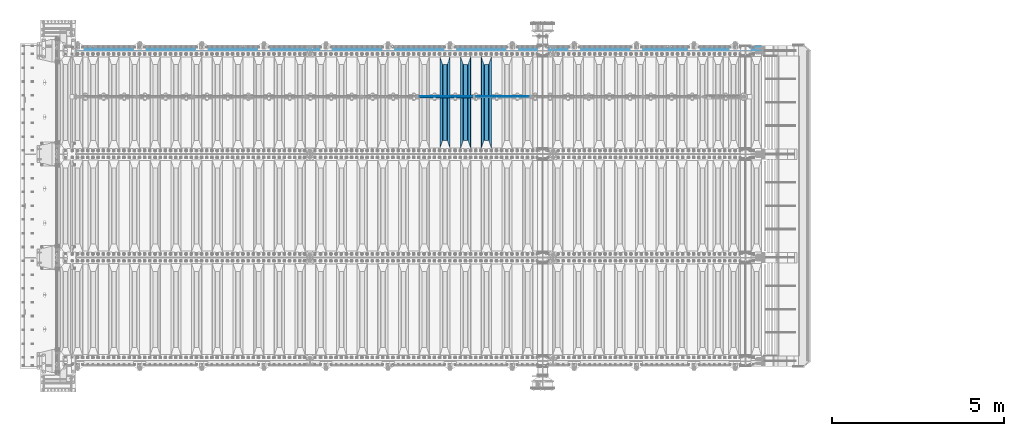
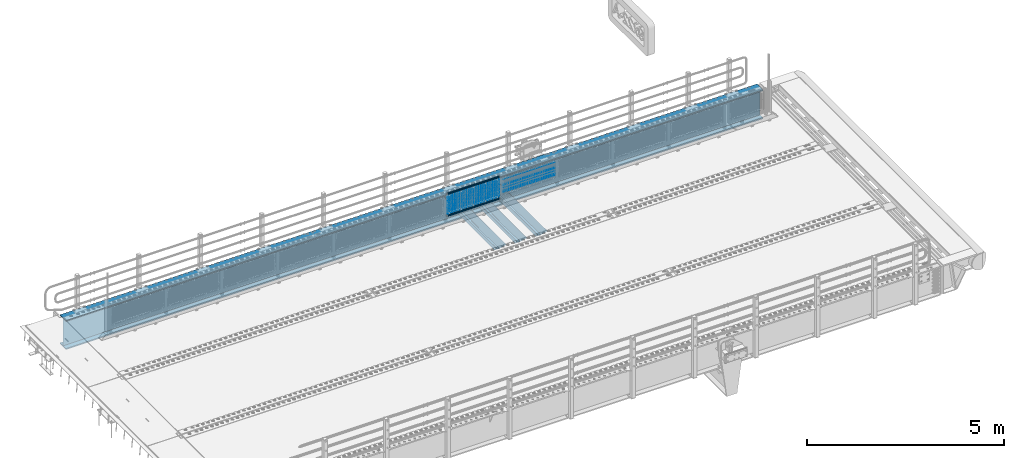
# One storey, part 135 of 270: 30 beams.
"""IFC2X3 building model written with IfcOpenShell, lengths in millimetres."""

import ifcopenshell
import ifcopenshell.guid

model = None  # the IFC model being written
_history = None  # IfcOwnerHistory: only IFC2X3 demands one
_inside = {}  # id of a spatial element -> (the spatial element, [elements in it])
_under = {}  # id of a project, library or spatial element -> (it, [spatial elements below it])
_declared = {}  # id of a project -> (the project, [libraries it declares])
_typed = {}  # id of a type object -> (the type object, [elements of that type])
_made_of = {}  # id of a material, layer set ... -> (it, [elements and type objects made of it])


def new_model(schema):
    """Start an empty IFC model of exactly this schema.

    Asked for "IFC4X3", IfcOpenShell would pick the latest addendum, in which some entities
    have other attributes; the version numbers below select the first issue.
    IFC2X3 requires an IfcOwnerHistory on every rooted entity: one is made here for all.
    """
    global model, _history
    if schema == "IFC4X3":
        model = ifcopenshell.file(schema_version=(4, 3, 0, 0))
    else:
        model = ifcopenshell.file(schema=schema)
    _inside.clear()
    _under.clear()
    _declared.clear()
    _typed.clear()
    _made_of.clear()
    _history = None
    if model.schema == "IFC2X3":
        org = make("IfcOrganization", Name="unknown")
        user = make(
            "IfcPersonAndOrganization",
            ThePerson=make("IfcPerson", FamilyName="unknown"),
            TheOrganization=org,
        )
        app = make(
            "IfcApplication",
            ApplicationDeveloper=org,
            Version="unknown",
            ApplicationFullName="unknown",
            ApplicationIdentifier="unknown",
        )
        _history = make(
            "IfcOwnerHistory",
            OwningUser=user,
            OwningApplication=app,
            ChangeAction="ADDED",
            CreationDate=0,
        )
    return model


def make(cls, **values):
    """One entity of the class cls with the attributes given. An attribute that is None is left unset."""
    return model.create_entity(
        cls, **{name: value for name, value in values.items() if value is not None}
    )


def rooted(cls, **values):
    """An entity with a GlobalId (a new one), such as an element, a storey or a relation."""
    return make(cls, GlobalId=ifcopenshell.guid.new(), OwnerHistory=_history, **values)


def si_unit(unit_type, name, prefix=None):
    """IfcSIUnit, for example si_unit("LENGTHUNIT", "METRE", prefix="MILLI")."""
    return make("IfcSIUnit", UnitType=unit_type, Prefix=prefix, Name=name)


def assignment(units):
    """IfcUnitAssignment: the units of a project."""
    return None if units is None else make("IfcUnitAssignment", Units=units)


def point(xyz):
    """IfcCartesianPoint."""
    return None if xyz is None else make("IfcCartesianPoint", Coordinates=xyz)


def direction(xyz):
    """IfcDirection."""
    return None if xyz is None else make("IfcDirection", DirectionRatios=xyz)


def frame(location, z_axis=None, x_axis=None):
    """IfcAxis2Placement3D, a coordinate frame: its origin and axes. An axis left out is left unset."""
    return make(
        "IfcAxis2Placement3D",
        Location=point(location),
        Axis=direction(z_axis),
        RefDirection=direction(x_axis),
    )


def origin_with_axes():
    """The frame at (0, 0, 0) with the z axis (0, 0, 1) and the x axis (1, 0, 0) written out."""
    return frame((0.0, 0.0, 0.0), z_axis=(0.0, 0.0, 1.0), x_axis=(1.0, 0.0, 0.0))


def place(relative_to, where):
    """IfcLocalPlacement: puts the frame where relative to a parent placement (None: the world)."""
    return make(
        "IfcLocalPlacement", PlacementRelTo=relative_to, RelativePlacement=where
    )


def context(
    kind, dimensions, precision=None, world=None, true_north=None, identifier=None
):
    """IfcGeometricRepresentationContext, for example the 3D "Model" context."""
    return make(
        "IfcGeometricRepresentationContext",
        ContextIdentifier=identifier,
        ContextType=kind,
        CoordinateSpaceDimension=dimensions,
        Precision=precision,
        WorldCoordinateSystem=world,
        TrueNorth=true_north,
    )


def subcontext(parent, identifier, kind, view, scale=None):
    """IfcGeometricRepresentationSubContext, for example "Body" below "Model"."""
    return make(
        "IfcGeometricRepresentationSubContext",
        ContextIdentifier=identifier,
        ContextType=kind,
        ParentContext=parent,
        TargetScale=scale,
        TargetView=view,
    )


def project(units=None, contexts=None):
    """IfcProject with its units and contexts."""
    return rooted(
        "IfcProject",
        Name="project",
        RepresentationContexts=contexts,
        UnitsInContext=assignment(units),
    )


def spatial(cls, under=None, at=None, **own):
    """A site, building, storey or space (cls), placed at a placement, below another one or the project."""
    s = rooted(cls, ObjectPlacement=at, **own)
    if under is not None:
        _under.setdefault(under.id(), (under, []))[1].append(s)
    return s


def faces_of(points, faces, orient=None, outer=None):
    """IfcFace entities. A face is a list of loops; a loop is a list of indices into points, from 0.

    orient and outer hold one flag for each loop. By default every Orientation is true, the
    first loop of a face is its IfcFaceOuterBound and the others are IfcFaceBound.
    """
    made = []
    for i, loops in enumerate(faces):
        bounds = []
        for j, loop in enumerate(loops):
            is_outer = j == 0 if outer is None else outer[i][j]
            bounds.append(
                make(
                    "IfcFaceOuterBound" if is_outer else "IfcFaceBound",
                    Bound=make("IfcPolyLoop", Polygon=[points[k] for k in loop]),
                    Orientation=True if orient is None else orient[i][j],
                )
            )
        made.append(make("IfcFace", Bounds=bounds))
    return made


def faceted_brep(points, faces, orient=None, outer=None, voids=None):
    """IfcFacetedBrep: a solid bounded by flat faces; with voids (closed shells), ...WithVoids."""
    shared = [point(p) for p in points]
    hull = make("IfcClosedShell", CfsFaces=faces_of(shared, faces, orient, outer))
    if voids is None:
        return make("IfcFacetedBrep", Outer=hull)
    return make(
        "IfcFacetedBrepWithVoids",
        Outer=hull,
        Voids=[
            make(cls, CfsFaces=faces_of(shared, fs, o, b)) for cls, fs, o, b in voids
        ],
    )


def shape(context_of_items, identifier, shape_type, items):
    """IfcShapeRepresentation: the items that make up one representation, for example the "Body"."""
    return make(
        "IfcShapeRepresentation",
        ContextOfItems=context_of_items,
        RepresentationIdentifier=identifier,
        RepresentationType=shape_type,
        Items=items,
    )


def material(Name=None, Category=None):
    """IfcMaterial."""
    return make("IfcMaterial", Name=Name, Category=Category)


def made_of(thing, what):
    """Note that an element or type object is made of a material, layer set ...; save() writes the relation."""
    if what is not None:
        _made_of.setdefault(what.id(), (what, []))[1].append(thing)
    return thing


def type_object(cls, material=None, **own):
    """A type object (cls), such as IfcWallType, which elements share."""
    return made_of(rooted(cls, **own), material)


def element(
    cls,
    number,
    at=None,
    inside=None,
    cuts=None,
    type_object=None,
    material=None,
    context=None,
    identifier="Body",
    shape_type=None,
    held_by="IfcProductDefinitionShape",
    body=None,
    shapes=None,
    **own,
):
    """One element of the class cls, such as IfcWall. Its Tag is "e" and its number.

    at: its placement. inside: the storey or other place that contains it. cuts: it is an
    opening in that element (IfcRelVoidsElement). A single representation is given by context,
    identifier, shape_type and body (its items); several are given by shapes. held_by: the class
    of the entity that holds the representations. save() writes the other relations.
    """
    e = rooted(cls, Tag="e%d" % number, ObjectPlacement=at, **own)
    if body is not None:
        shapes = [shape(context, identifier, shape_type, body)]
    if shapes is not None:
        e.Representation = make(held_by, Representations=shapes)
    if inside is not None:
        _inside.setdefault(inside.id(), (inside, []))[1].append(e)
    if cuts is not None:
        rooted(
            "IfcRelVoidsElement", RelatingBuildingElement=cuts, RelatedOpeningElement=e
        )
    if type_object is not None:
        _typed.setdefault(type_object.id(), (type_object, []))[1].append(e)
    return made_of(e, material)


def aggregate(whole, parts):
    """IfcRelAggregates: a whole, such as a stair, and the parts it consists of."""
    return rooted("IfcRelAggregates", RelatingObject=whole, RelatedObjects=parts)


def save(model, path):
    """Write the relations noted so far, then the file.

    IfcRelAggregates (storeys below a building ...), IfcRelContainedInSpatialStructure (elements
    in a storey), IfcRelDefinesByType, IfcRelAssociatesMaterial and IfcRelDeclares: one each for
    every whole, place, type object, material and project.
    """
    for whole, parts in _under.values():
        aggregate(whole, parts)
    for where, things in _inside.values():
        rooted(
            "IfcRelContainedInSpatialStructure",
            RelatedElements=things,
            RelatingStructure=where,
        )
    for kind, things in _typed.values():
        rooted("IfcRelDefinesByType", RelatedObjects=things, RelatingType=kind)
    for what, things in _made_of.values():
        rooted("IfcRelAssociatesMaterial", RelatedObjects=things, RelatingMaterial=what)
    for by, libraries in _declared.values():
        rooted("IfcRelDeclares", RelatingContext=by, RelatedDefinitions=libraries)
    model.write(path)


model = new_model("IFC2X3")

# Units and contexts
model_context = context("Model", 3, precision=1e-05, world=origin_with_axes())
body_context = subcontext(model_context, "Body", "Model", "MODEL_VIEW")
ifc_project = project(units=[si_unit("LENGTHUNIT", "METRE", prefix="MILLI"), si_unit("AREAUNIT", "SQUARE_METRE"), si_unit("VOLUMEUNIT", "CUBIC_METRE"), si_unit("MASSUNIT", "GRAM", prefix="KILO"), si_unit("TIMEUNIT", "SECOND"), si_unit("PLANEANGLEUNIT", "RADIAN"), si_unit("SOLIDANGLEUNIT", "STERADIAN"), si_unit("THERMODYNAMICTEMPERATUREUNIT", "DEGREE_CELSIUS"), si_unit("LUMINOUSINTENSITYUNIT", "LUMEN")], contexts=[model_context])

# Site, building, storey
site_placement = place(None, origin_with_axes())
site = spatial("IfcSite", under=ifc_project, at=site_placement, CompositionType="ELEMENT")
building_placement = place(site_placement, origin_with_axes())
building = spatial("IfcBuilding", under=site, at=building_placement, Name="Standard", CompositionType="ELEMENT")
storey_placement = place(building_placement, origin_with_axes())
storey = spatial("IfcBuildingStorey", under=building, at=storey_placement, Name="Undefined", CompositionType="ELEMENT", Elevation=0.0)

# Beams
ifc_material_1 = material(Name="STEEL/S355N")
beam_type_1 = type_object("IfcBeamType", PredefinedType="NOTDEFINED")
beam_1_placement = place(storey_placement, frame((12400.0, -17825.0, -115.0), z_axis=(0.0, 0.0, 1.0), x_axis=(0.0, 1.0, 0.0)))
element("IfcBeam", 1, at=beam_1_placement, inside=storey, type_object=beam_type_1, material=ifc_material_1, context=body_context, shape_type="Brep", body=[
    faceted_brep([(0.0, 150.0, 115.0), (0.0, 143.689999999999, 115.0), (2650.00000000297, 143.689999999999, 115.0), (2650.00000000297, 150.0, 115.0), (2650.00000000297, 142.059565218398, 110.000000003096), (2650.00000000297, 148.3695652184, 110.000000003096), (2441.90079219209, -80.1103600731112, -98.0992078077845), (2437.7588105432, -77.5672621345584, -102.241189456673), (2434.06523489747, -74.4080125315522, -105.934765102404), (2430.9108609509, -70.710272125576, -109.089139048974), (2428.37322971128, -66.5649389910068, -111.626770288588), (2426.51472138055, -62.0739139532889, -113.485278619323), (2425.38102192092, -57.3475956567672, -114.618978078955), (2424.99999999987, -52.5021667386536, -115.0), (2424.99999999987, 52.5021667386536, -115.0), (2425.38102192092, 57.3475956567672, -114.618978078955), (2426.51472138055, 62.0739139532889, -113.485278619323), (2428.37322971128, 66.5649389910068, -111.626770288588), (2430.9108609509, 70.710272125576, -109.089139048974), (2434.06523489747, 74.4080125315522, -105.934765102404), (2437.7588105432, 77.5672621345584, -102.241189456673), (2441.90079219209, 80.1103600731112, -98.0992078077846), (2446.38936140511, 81.9747917625791, -93.6106385947584), (2448.2494850041, 76.2713538057251, -91.7505149957729), (2444.62967112263, 74.76777986261, -95.3703288772456), (2441.28936334126, 72.7168944282894, -98.710636658607), (2438.31067330439, 70.1691124903846, -101.689326695487), (2435.76682334747, 67.1870637758839, -104.233176652398), (2433.72034654133, 63.8440531834895, -106.279653458539), (2432.22154950042, 60.222258798236, -107.778450499454), (2431.30727574265, 56.4107117849089, -108.692724257221), (2430.99999999987, 52.5031078186876, -109.0), (2430.99999999987, -52.5031078186876, -109.0), (2431.30727574265, -56.4107117849089, -108.692724257221), (2432.22154950042, -60.222258798236, -107.778450499454), (2433.72034654133, -63.8440531834895, -106.279653458539), (2435.76682334747, -67.1870637758839, -104.233176652398), (2438.31067330438, -70.1691124903846, -101.689326695487), (2441.28936334126, -72.7168944282894, -98.7106366586071), (2444.62967112263, -74.76777986261, -95.3703288772457), (2448.2494850041, -76.2713538057251, -91.7505149957729), (2650.00000000297, -142.059565218398, 110.000000003096), (2650.00000000297, -148.3695652184, 110.000000003096), (2446.38936140511, -81.9747917625791, -93.6106385947584), (2650.00000000297, -143.689999999999, 115.0), (2650.00000000297, -150.0, 115.0), (0.0, -143.689999999999, 115.0), (0.0, -150.0, 115.0), (0.0, -148.369565218261, 110.000000002672), (203.610638597431, -81.9747917625791, -93.6106385947584), (208.099207810457, -80.1103600731112, -98.0992078077845), (212.241189459342, -77.5672621345584, -102.241189456673), (215.934765105078, -74.4080125315522, -105.934765102404), (219.089139051644, -70.710272125576, -109.089139048974), (221.626770291259, -66.5649389910068, -111.626770288588), (223.485278621993, -62.0739139532889, -113.485278619323), (224.618978081628, -57.3475956567672, -114.618978078955), (225.00000000267, -52.5021667386536, -115.0), (225.00000000267, 52.5021667386536, -115.0), (224.618978081628, 57.3475956567672, -114.618978078955), (223.485278621993, 62.0739139532889, -113.485278619323), (221.626770291259, 66.5649389910068, -111.626770288588), (219.089139051644, 70.710272125576, -109.089139048974), (215.934765105078, 74.4080125315522, -105.934765102404), (212.241189459342, 77.5672621345584, -102.241189456673), (208.099207810457, 80.1103600731112, -98.0992078077846), (203.610638597431, 81.9747917625791, -93.6106385947584), (0.0, 148.369565218261, 110.000000002672), (0.0, 142.05956521826, 110.000000002672), (201.750514998446, 76.2713538057251, -91.7505149957729), (205.370328879915, 74.76777986261, -95.3703288772456), (208.710636661279, 72.7168944282894, -98.710636658607), (211.689326698157, 70.1691124903846, -101.689326695487), (214.233176655071, 67.1870637758839, -104.233176652398), (216.27965346121, 63.8440531834895, -106.279653458539), (217.778450502126, 60.222258798236, -107.778450499454), (218.692724259894, 56.4107117849089, -108.692724257221), (219.00000000267, 52.5031078186876, -109.0), (219.00000000267, -52.5031078186876, -109.0), (218.692724259894, -56.4107117849089, -108.692724257221), (217.778450502123, -60.222258798236, -107.778450499454), (216.27965346121, -63.8440531834895, -106.279653458539), (214.233176655071, -67.1870637758839, -104.233176652398), (211.689326698157, -70.1691124903846, -101.689326695487), (208.710636661279, -72.7168944282894, -98.7106366586071), (205.370328879915, -74.76777986261, -95.3703288772457), (201.750514998446, -76.2713538057251, -91.7505149957729), (0.0, -142.05956521826, 110.000000002672)], [[[0, 1, 2, 3]], [[3, 2, 4, 5]], [[6, 7, 8, 9, 10, 11, 12, 13, 14, 15, 16, 17, 18, 19, 20, 21, 22, 5, 4, 23, 24, 25, 26, 27, 28, 29, 30, 31, 32, 33, 34, 35, 36, 37, 38, 39, 40, 41, 42, 43]], [[44, 45, 42, 41]], [[46, 47, 45, 44]], [[43, 42, 45, 47, 48, 49]], [[6, 43, 49, 50]], [[7, 6, 50, 51]], [[8, 7, 51, 52]], [[9, 8, 52, 53]], [[10, 9, 53, 54]], [[11, 10, 54, 55]], [[12, 11, 55, 56]], [[13, 12, 56, 57]], [[14, 13, 57, 58]], [[15, 14, 58, 59]], [[16, 15, 59, 60]], [[17, 16, 60, 61]], [[18, 17, 61, 62]], [[19, 18, 62, 63]], [[20, 19, 63, 64]], [[21, 20, 64, 65]], [[22, 21, 65, 66]], [[0, 3, 5, 22, 66, 67]], [[1, 0, 67, 68]], [[23, 4, 2, 1, 68, 69]], [[24, 23, 69, 70]], [[25, 24, 70, 71]], [[26, 25, 71, 72]], [[27, 26, 72, 73]], [[28, 27, 73, 74]], [[29, 28, 74, 75]], [[30, 29, 75, 76]], [[31, 30, 76, 77]], [[32, 31, 77, 78]], [[33, 32, 78, 79]], [[34, 33, 79, 80]], [[35, 34, 80, 81]], [[36, 35, 81, 82]], [[37, 36, 82, 83]], [[38, 37, 83, 84]], [[39, 38, 84, 85]], [[40, 39, 85, 86]], [[46, 44, 41, 40, 86, 87]], [[47, 46, 87, 48]], [[86, 85, 84, 83, 82, 81, 80, 79, 78, 77, 76, 75, 74, 73, 72, 71, 70, 69, 68, 67, 66, 65, 64, 63, 62, 61, 60, 59, 58, 57, 56, 55, 54, 53, 52, 51, 50, 49, 48, 87]]]),
])
beam_2_placement = place(storey_placement, frame((11800.0, -17825.0, -115.0), z_axis=(0.0, 0.0, 1.0), x_axis=(0.0, 1.0, 0.0)))
element("IfcBeam", 2, at=beam_2_placement, inside=storey, type_object=beam_type_1, material=ifc_material_1, context=body_context, shape_type="Brep", body=[
    faceted_brep([(0.0, 150.0, 115.0), (0.0, 143.689999999999, 115.0), (2650.00000000297, 143.689999999999, 115.0), (2650.00000000297, 150.0, 115.0), (2650.00000000297, 142.059565218398, 110.000000003096), (2650.00000000297, 148.3695652184, 110.000000003096), (2441.90079219209, -80.1103600731112, -98.0992078077845), (2437.7588105432, -77.5672621345584, -102.241189456673), (2434.06523489747, -74.4080125315522, -105.934765102404), (2430.9108609509, -70.710272125576, -109.089139048974), (2428.37322971128, -66.5649389910068, -111.626770288588), (2426.51472138055, -62.0739139532889, -113.485278619323), (2425.38102192092, -57.3475956567672, -114.618978078955), (2424.99999999987, -52.5021667386536, -115.0), (2424.99999999987, 52.5021667386536, -115.0), (2425.38102192092, 57.3475956567672, -114.618978078955), (2426.51472138055, 62.0739139532889, -113.485278619323), (2428.37322971128, 66.5649389910068, -111.626770288588), (2430.9108609509, 70.710272125576, -109.089139048974), (2434.06523489747, 74.4080125315522, -105.934765102404), (2437.7588105432, 77.5672621345584, -102.241189456673), (2441.90079219209, 80.1103600731112, -98.0992078077846), (2446.38936140511, 81.9747917625791, -93.6106385947584), (2448.2494850041, 76.2713538057251, -91.7505149957729), (2444.62967112263, 74.76777986261, -95.3703288772456), (2441.28936334126, 72.7168944282894, -98.710636658607), (2438.31067330439, 70.1691124903846, -101.689326695487), (2435.76682334747, 67.1870637758839, -104.233176652398), (2433.72034654133, 63.8440531834895, -106.279653458539), (2432.22154950042, 60.222258798236, -107.778450499454), (2431.30727574265, 56.4107117849089, -108.692724257221), (2430.99999999987, 52.5031078186876, -109.0), (2430.99999999987, -52.5031078186876, -109.0), (2431.30727574265, -56.4107117849089, -108.692724257221), (2432.22154950042, -60.222258798236, -107.778450499454), (2433.72034654133, -63.8440531834895, -106.279653458539), (2435.76682334747, -67.1870637758839, -104.233176652398), (2438.31067330438, -70.1691124903846, -101.689326695487), (2441.28936334126, -72.7168944282894, -98.7106366586071), (2444.62967112263, -74.76777986261, -95.3703288772457), (2448.2494850041, -76.2713538057251, -91.7505149957729), (2650.00000000297, -142.059565218398, 110.000000003096), (2650.00000000297, -148.3695652184, 110.000000003096), (2446.38936140511, -81.9747917625791, -93.6106385947584), (2650.00000000297, -143.689999999999, 115.0), (2650.00000000297, -150.0, 115.0), (0.0, -143.689999999999, 115.0), (0.0, -150.0, 115.0), (0.0, -148.369565218261, 110.000000002672), (203.610638597431, -81.9747917625791, -93.6106385947584), (208.099207810457, -80.1103600731112, -98.0992078077845), (212.241189459342, -77.5672621345584, -102.241189456673), (215.934765105078, -74.4080125315522, -105.934765102404), (219.089139051644, -70.710272125576, -109.089139048974), (221.626770291259, -66.5649389910068, -111.626770288588), (223.485278621993, -62.0739139532889, -113.485278619323), (224.618978081628, -57.3475956567672, -114.618978078955), (225.00000000267, -52.5021667386536, -115.0), (225.00000000267, 52.5021667386536, -115.0), (224.618978081628, 57.3475956567672, -114.618978078955), (223.485278621993, 62.0739139532889, -113.485278619323), (221.626770291259, 66.5649389910068, -111.626770288588), (219.089139051644, 70.710272125576, -109.089139048974), (215.934765105078, 74.4080125315522, -105.934765102404), (212.241189459342, 77.5672621345584, -102.241189456673), (208.099207810457, 80.1103600731112, -98.0992078077846), (203.610638597431, 81.9747917625791, -93.6106385947584), (0.0, 148.369565218261, 110.000000002672), (0.0, 142.05956521826, 110.000000002672), (201.750514998446, 76.2713538057251, -91.7505149957729), (205.370328879915, 74.76777986261, -95.3703288772456), (208.710636661279, 72.7168944282894, -98.710636658607), (211.689326698157, 70.1691124903846, -101.689326695487), (214.233176655071, 67.1870637758839, -104.233176652398), (216.27965346121, 63.8440531834895, -106.279653458539), (217.778450502126, 60.222258798236, -107.778450499454), (218.692724259894, 56.4107117849089, -108.692724257221), (219.00000000267, 52.5031078186876, -109.0), (219.00000000267, -52.5031078186876, -109.0), (218.692724259894, -56.4107117849089, -108.692724257221), (217.778450502123, -60.222258798236, -107.778450499454), (216.27965346121, -63.8440531834895, -106.279653458539), (214.233176655071, -67.1870637758839, -104.233176652398), (211.689326698157, -70.1691124903846, -101.689326695487), (208.710636661279, -72.7168944282894, -98.7106366586071), (205.370328879915, -74.76777986261, -95.3703288772457), (201.750514998446, -76.2713538057251, -91.7505149957729), (0.0, -142.05956521826, 110.000000002672)], [[[0, 1, 2, 3]], [[3, 2, 4, 5]], [[6, 7, 8, 9, 10, 11, 12, 13, 14, 15, 16, 17, 18, 19, 20, 21, 22, 5, 4, 23, 24, 25, 26, 27, 28, 29, 30, 31, 32, 33, 34, 35, 36, 37, 38, 39, 40, 41, 42, 43]], [[44, 45, 42, 41]], [[46, 47, 45, 44]], [[43, 42, 45, 47, 48, 49]], [[6, 43, 49, 50]], [[7, 6, 50, 51]], [[8, 7, 51, 52]], [[9, 8, 52, 53]], [[10, 9, 53, 54]], [[11, 10, 54, 55]], [[12, 11, 55, 56]], [[13, 12, 56, 57]], [[14, 13, 57, 58]], [[15, 14, 58, 59]], [[16, 15, 59, 60]], [[17, 16, 60, 61]], [[18, 17, 61, 62]], [[19, 18, 62, 63]], [[20, 19, 63, 64]], [[21, 20, 64, 65]], [[22, 21, 65, 66]], [[0, 3, 5, 22, 66, 67]], [[1, 0, 67, 68]], [[23, 4, 2, 1, 68, 69]], [[24, 23, 69, 70]], [[25, 24, 70, 71]], [[26, 25, 71, 72]], [[27, 26, 72, 73]], [[28, 27, 73, 74]], [[29, 28, 74, 75]], [[30, 29, 75, 76]], [[31, 30, 76, 77]], [[32, 31, 77, 78]], [[33, 32, 78, 79]], [[34, 33, 79, 80]], [[35, 34, 80, 81]], [[36, 35, 81, 82]], [[37, 36, 82, 83]], [[38, 37, 83, 84]], [[39, 38, 84, 85]], [[40, 39, 85, 86]], [[46, 44, 41, 40, 86, 87]], [[47, 46, 87, 48]], [[86, 85, 84, 83, 82, 81, 80, 79, 78, 77, 76, 75, 74, 73, 72, 71, 70, 69, 68, 67, 66, 65, 64, 63, 62, 61, 60, 59, 58, 57, 56, 55, 54, 53, 52, 51, 50, 49, 48, 87]]]),
])
beam_3_placement = place(storey_placement, frame((11200.0, -17825.0, -115.0), z_axis=(0.0, 0.0, 1.0), x_axis=(0.0, 1.0, 0.0)))
element("IfcBeam", 3, at=beam_3_placement, inside=storey, type_object=beam_type_1, material=ifc_material_1, context=body_context, shape_type="Brep", body=[
    faceted_brep([(0.0, 150.0, 115.0), (0.0, 143.689999999999, 115.0), (2650.00000000297, 143.689999999999, 115.0), (2650.00000000297, 150.0, 115.0), (2650.00000000297, 142.059565218398, 110.000000003096), (2650.00000000297, 148.3695652184, 110.000000003096), (2441.90079219209, -80.1103600731112, -98.0992078077845), (2437.7588105432, -77.5672621345584, -102.241189456673), (2434.06523489747, -74.4080125315522, -105.934765102404), (2430.9108609509, -70.710272125576, -109.089139048974), (2428.37322971128, -66.5649389910068, -111.626770288588), (2426.51472138055, -62.0739139532889, -113.485278619323), (2425.38102192092, -57.3475956567672, -114.618978078955), (2424.99999999987, -52.5021667386536, -115.0), (2424.99999999987, 52.5021667386536, -115.0), (2425.38102192092, 57.3475956567672, -114.618978078955), (2426.51472138055, 62.0739139532889, -113.485278619323), (2428.37322971128, 66.5649389910068, -111.626770288588), (2430.9108609509, 70.710272125576, -109.089139048974), (2434.06523489747, 74.4080125315522, -105.934765102404), (2437.7588105432, 77.5672621345584, -102.241189456673), (2441.90079219209, 80.1103600731112, -98.0992078077846), (2446.38936140511, 81.9747917625791, -93.6106385947584), (2448.2494850041, 76.2713538057251, -91.7505149957729), (2444.62967112263, 74.76777986261, -95.3703288772456), (2441.28936334126, 72.7168944282894, -98.710636658607), (2438.31067330439, 70.1691124903846, -101.689326695487), (2435.76682334747, 67.1870637758839, -104.233176652398), (2433.72034654133, 63.8440531834895, -106.279653458539), (2432.22154950042, 60.222258798236, -107.778450499454), (2431.30727574265, 56.4107117849089, -108.692724257221), (2430.99999999987, 52.5031078186876, -109.0), (2430.99999999987, -52.5031078186876, -109.0), (2431.30727574265, -56.4107117849089, -108.692724257221), (2432.22154950042, -60.222258798236, -107.778450499454), (2433.72034654133, -63.8440531834895, -106.279653458539), (2435.76682334747, -67.1870637758839, -104.233176652398), (2438.31067330438, -70.1691124903846, -101.689326695487), (2441.28936334126, -72.7168944282894, -98.7106366586071), (2444.62967112263, -74.76777986261, -95.3703288772457), (2448.2494850041, -76.2713538057251, -91.7505149957729), (2650.00000000297, -142.059565218398, 110.000000003096), (2650.00000000297, -148.3695652184, 110.000000003096), (2446.38936140511, -81.9747917625791, -93.6106385947584), (2650.00000000297, -143.689999999999, 115.0), (2650.00000000297, -150.0, 115.0), (0.0, -143.689999999999, 115.0), (0.0, -150.0, 115.0), (0.0, -148.369565218261, 110.000000002672), (203.610638597431, -81.9747917625791, -93.6106385947584), (208.099207810457, -80.1103600731112, -98.0992078077845), (212.241189459342, -77.5672621345584, -102.241189456673), (215.934765105078, -74.4080125315522, -105.934765102404), (219.089139051644, -70.710272125576, -109.089139048974), (221.626770291259, -66.5649389910068, -111.626770288588), (223.485278621993, -62.0739139532889, -113.485278619323), (224.618978081628, -57.3475956567672, -114.618978078955), (225.00000000267, -52.5021667386536, -115.0), (225.00000000267, 52.5021667386536, -115.0), (224.618978081628, 57.3475956567672, -114.618978078955), (223.485278621993, 62.0739139532889, -113.485278619323), (221.626770291259, 66.5649389910068, -111.626770288588), (219.089139051644, 70.710272125576, -109.089139048974), (215.934765105078, 74.4080125315522, -105.934765102404), (212.241189459342, 77.5672621345584, -102.241189456673), (208.099207810457, 80.1103600731112, -98.0992078077846), (203.610638597431, 81.9747917625791, -93.6106385947584), (0.0, 148.369565218261, 110.000000002672), (0.0, 142.05956521826, 110.000000002672), (201.750514998446, 76.2713538057251, -91.7505149957729), (205.370328879915, 74.76777986261, -95.3703288772456), (208.710636661279, 72.7168944282894, -98.710636658607), (211.689326698157, 70.1691124903846, -101.689326695487), (214.233176655071, 67.1870637758839, -104.233176652398), (216.27965346121, 63.8440531834895, -106.279653458539), (217.778450502126, 60.222258798236, -107.778450499454), (218.692724259894, 56.4107117849089, -108.692724257221), (219.00000000267, 52.5031078186876, -109.0), (219.00000000267, -52.5031078186876, -109.0), (218.692724259894, -56.4107117849089, -108.692724257221), (217.778450502123, -60.222258798236, -107.778450499454), (216.27965346121, -63.8440531834895, -106.279653458539), (214.233176655071, -67.1870637758839, -104.233176652398), (211.689326698157, -70.1691124903846, -101.689326695487), (208.710636661279, -72.7168944282894, -98.7106366586071), (205.370328879915, -74.76777986261, -95.3703288772457), (201.750514998446, -76.2713538057251, -91.7505149957729), (0.0, -142.05956521826, 110.000000002672)], [[[0, 1, 2, 3]], [[3, 2, 4, 5]], [[6, 7, 8, 9, 10, 11, 12, 13, 14, 15, 16, 17, 18, 19, 20, 21, 22, 5, 4, 23, 24, 25, 26, 27, 28, 29, 30, 31, 32, 33, 34, 35, 36, 37, 38, 39, 40, 41, 42, 43]], [[44, 45, 42, 41]], [[46, 47, 45, 44]], [[43, 42, 45, 47, 48, 49]], [[6, 43, 49, 50]], [[7, 6, 50, 51]], [[8, 7, 51, 52]], [[9, 8, 52, 53]], [[10, 9, 53, 54]], [[11, 10, 54, 55]], [[12, 11, 55, 56]], [[13, 12, 56, 57]], [[14, 13, 57, 58]], [[15, 14, 58, 59]], [[16, 15, 59, 60]], [[17, 16, 60, 61]], [[18, 17, 61, 62]], [[19, 18, 62, 63]], [[20, 19, 63, 64]], [[21, 20, 64, 65]], [[22, 21, 65, 66]], [[0, 3, 5, 22, 66, 67]], [[1, 0, 67, 68]], [[23, 4, 2, 1, 68, 69]], [[24, 23, 69, 70]], [[25, 24, 70, 71]], [[26, 25, 71, 72]], [[27, 26, 72, 73]], [[28, 27, 73, 74]], [[29, 28, 74, 75]], [[30, 29, 75, 76]], [[31, 30, 76, 77]], [[32, 31, 77, 78]], [[33, 32, 78, 79]], [[34, 33, 79, 80]], [[35, 34, 80, 81]], [[36, 35, 81, 82]], [[37, 36, 82, 83]], [[38, 37, 83, 84]], [[39, 38, 84, 85]], [[40, 39, 85, 86]], [[46, 44, 41, 40, 86, 87]], [[47, 46, 87, 48]], [[86, 85, 84, 83, 82, 81, 80, 79, 78, 77, 76, 75, 74, 73, 72, 71, 70, 69, 68, 67, 66, 65, 64, 63, 62, 61, 60, 59, 58, 57, 56, 55, 54, 53, 52, 51, 50, 49, 48, 87]]]),
])
ifc_material_2 = material(Name="Misc_Undefined")
beam_type_2 = type_object("IfcBeamType", Name="D3", PredefinedType="NOTDEFINED")
for number, where, z_axis, x_axis in (
    (4, (12107.0, -16329.5, 851.596999999999), (0.0, 0.0, 1.0), (1.0, 0.0, 0.0)),
    (5, (12107.0, -16329.5, 669.452), (0.0, 0.0, 1.0), (1.0, 0.0, 0.0)),
    (6, (12107.0, -16329.5, 523.736), (0.0, 0.0, 1.0), (1.0, 0.0, 0.0)),
    (7, (12107.0, -16329.5, 487.307), (0.0, 0.0, 1.0), (1.0, 0.0, 0.0)),
    (8, (12107.0, -16329.5, 705.881), (0.0, 0.0, 1.0), (1.0, 0.0, 0.0)),
    (9, (12107.0, -16329.5, 596.594), (0.0, 0.0, 1.0), (1.0, 0.0, 0.0)),
    (10, (12107.0, -16329.5, 450.878), (0.0, 0.0, 1.0), (1.0, 0.0, 0.0)),
    (11, (10474.0, -16329.5, 851.596999999999), (0.0, 0.0, 1.0), (1.0, 0.0, 0.0)),
    (12, (10474.0, -16329.5, 669.452), (0.0, 0.0, 1.0), (1.0, 0.0, 0.0)),
    (13, (10474.0, -16329.5, 523.736), (0.0, 0.0, 1.0), (1.0, 0.0, 0.0)),
    (14, (10474.0, -16329.5, 487.307), (0.0, 0.0, 1.0), (1.0, 0.0, 0.0)),
    (15, (10474.0, -16329.5, 705.881), (0.0, 0.0, 1.0), (1.0, 0.0, 0.0)),
    (16, (10474.0, -16329.5, 596.594), (0.0, 0.0, 1.0), (1.0, 0.0, 0.0)),
    (17, (10474.0, -16329.5, 450.878), (0.0, 0.0, 1.0), (1.0, 0.0, 0.0)),
    (18, (10474.0, -16329.5, 815.167999999999), (0.0, 0.0, 1.0), (1.0, 0.0, 0.0)),
    (19, (10474.0, -16329.5, 888.025999999999), (0.0, 0.0, 1.0), (1.0, 0.0, 0.0)),
    (20, (10474.0, -16329.5, 778.738999999999), (0.0, 0.0, 1.0), (1.0, 0.0, 0.0)),
    (21, (10474.0, -16329.5, 742.309999999999), (0.0, 0.0, 1.0), (1.0, 0.0, 0.0)),
    (22, (10474.0, -16329.5, 633.023), (0.0, 0.0, 1.0), (1.0, 0.0, 0.0)),
    (23, (10474.0, -16329.5, 560.165), (0.0, 0.0, 1.0), (1.0, 0.0, 0.0)),
    (24, (10474.0, -16329.5, 414.449), (0.0, 0.0, 1.0), (1.0, 0.0, 0.0)),
):
    element("IfcBeam", number, at=place(storey_placement, frame(where, z_axis=z_axis, x_axis=x_axis)), inside=storey, type_object=beam_type_2, material=ifc_material_2, ObjectType="D3", context=body_context, shape_type="Brep", body=[
        faceted_brep([(0.0, -1.5, 0.0), (0.0, -0.75, -1.29903810567669), (1523.0, -0.75, -1.29903810567669), (1523.0, -1.5, 0.0), (0.0, 0.75, -1.29903810567669), (1523.0, 0.75, -1.29903810567669), (0.0, 1.5, 0.0), (1523.0, 1.5, 0.0), (0.0, 0.75, 1.29903810567669), (1523.0, 0.75, 1.29903810567669), (0.0, -0.75, 1.29903810567669), (1523.0, -0.75, 1.29903810567669)], [[[0, 1, 2, 3]], [[1, 4, 5, 2]], [[4, 6, 7, 5]], [[6, 8, 9, 7]], [[8, 10, 11, 9]], [[10, 0, 3, 11]], [[5, 7, 9, 11, 3, 2]], [[10, 8, 6, 4, 1, 0]]]),
    ])
beam_4_placement = place(storey_placement, frame((10499.0, -16329.5, 353.02), z_axis=(0.0, 0.0, 1.0), x_axis=(1.0, 0.0, 0.0)))
element("IfcBeam", 25, at=beam_4_placement, inside=storey, type_object=beam_type_2, material=ifc_material_2, ObjectType="D3", context=body_context, shape_type="Brep", body=[
    faceted_brep([(0.0, -1.5, 0.0), (0.0, -0.75, -1.29903810567669), (1473.0, -0.75, -1.29903810567669), (1473.0, -1.5, 0.0), (0.0, 0.75, -1.29903810567669), (1473.0, 0.75, -1.29903810567663), (0.0, 1.5, 0.0), (1473.0, 1.5, 0.0), (0.0, 0.75, 1.29903810567669), (1473.0, 0.75, 1.29903810567669), (0.0, -0.75, 1.29903810567669), (1473.0, -0.75, 1.29903810567669)], [[[0, 1, 2, 3]], [[1, 4, 5, 2]], [[4, 6, 7, 5]], [[6, 8, 9, 7]], [[8, 10, 11, 9]], [[10, 0, 3, 11]], [[5, 7, 9, 11, 3, 2]], [[10, 8, 6, 4, 1, 0]]]),
])
beam_5_placement = place(storey_placement, frame((10474.0, -16329.5, 378.02), z_axis=(0.0, 0.0, 1.0), x_axis=(1.0, 0.0, 0.0)))
element("IfcBeam", 26, at=beam_5_placement, inside=storey, type_object=beam_type_2, material=ifc_material_2, ObjectType="D3", context=body_context, shape_type="Brep", body=[
    faceted_brep([(0.0, -1.5, 0.0), (0.0, -0.75, -1.29903810567669), (1523.0, -0.75, -1.29903810567669), (1523.0, -1.5, 0.0), (0.0, 0.75, -1.29903810567669), (1523.0, 0.75, -1.29903810567669), (0.0, 1.5, 0.0), (1523.0, 1.5, 0.0), (0.0, 0.75, 1.29903810567669), (1523.0, 0.75, 1.29903810567669), (0.0, -0.75, 1.29903810567669), (1523.0, -0.75, 1.29903810567669)], [[[0, 1, 2, 3]], [[1, 4, 5, 2]], [[4, 6, 7, 5]], [[6, 8, 9, 7]], [[8, 10, 11, 9]], [[10, 0, 3, 11]], [[5, 7, 9, 11, 3, 2]], [[10, 8, 6, 4, 1, 0]]]),
])
beam_6_placement = place(storey_placement, frame((10499.0, -16329.5, 913.02), z_axis=(0.0, 0.0, 1.0), x_axis=(1.0, 0.0, 0.0)))
element("IfcBeam", 27, at=beam_6_placement, inside=storey, type_object=beam_type_2, material=ifc_material_2, ObjectType="D3", context=body_context, shape_type="Brep", body=[
    faceted_brep([(0.0, -1.5, 0.0), (0.0, -0.75, -1.29903810567669), (1473.0, -0.75, -1.29903810567669), (1473.0, -1.5, 0.0), (0.0, 0.75, -1.29903810567669), (1473.0, 0.75, -1.29903810567663), (0.0, 1.5, 0.0), (1473.0, 1.5, 0.0), (0.0, 0.75, 1.29903810567669), (1473.0, 0.75, 1.29903810567669), (0.0, -0.75, 1.29903810567669), (1473.0, -0.75, 1.29903810567669)], [[[0, 1, 2, 3]], [[1, 4, 5, 2]], [[4, 6, 7, 5]], [[6, 8, 9, 7]], [[8, 10, 11, 9]], [[10, 0, 3, 11]], [[5, 7, 9, 11, 3, 2]], [[10, 8, 6, 4, 1, 0]]]),
])
ifc_material_3 = material()
beam_type_3 = type_object("IfcBeamType", PredefinedType="NOTDEFINED")
beam_7_placement = place(storey_placement, frame((10453.85, -16335.5, 969.849999999999), z_axis=(0.0, 0.0, 1.0), x_axis=(1.0, 0.0, 0.0)))
element("IfcBeam", 28, at=beam_7_placement, inside=storey, type_object=beam_type_3, material=ifc_material_3, context=body_context, shape_type="Brep", body=[
    faceted_brep([(0.0, -25.3500000000004, 0.0), (0.0, -23.4203461491616, 9.70102501045403), (1563.0, -23.4203461491616, 9.70102501045506), (1563.0, -25.3500000000004, 0.0), (0.0, -17.9251569030785, 17.9251569030785), (1563.0, -17.9251569030785, 17.925156903079), (0.0, -9.70102501045585, 23.4203461491597), (1563.0, -9.70102501045585, 23.4203461491611), (0.0, 0.0, 25.3499999999985), (1563.0, 0.0, 25.35), (0.0, 9.70102501045585, 23.4203461491597), (1563.0, 9.70102501045585, 23.4203461491611), (0.0, 17.9251569030785, 17.9251569030785), (1563.0, 17.9251569030785, 17.925156903079), (0.0, 23.4203461491616, 9.70102501045403), (1563.0, 23.4203461491616, 9.70102501045506), (0.0, 25.3500000000004, 0.0), (1563.0, 25.3500000000004, 0.0), (0.0, 23.4203461491616, -9.70102501045403), (1563.0, 23.4203461491616, -9.70102501045506), (0.0, 17.9251569030785, -17.9251569030785), (1563.0, 17.9251569030785, -17.925156903079), (0.0, 9.70102501045585, -23.4203461491597), (1563.0, 9.70102501045585, -23.4203461491611), (0.0, 0.0, -25.3499999999985), (1563.0, 0.0, -25.35), (0.0, -9.70102501045585, -23.4203461491597), (1563.0, -9.70102501045585, -23.4203461491611), (0.0, -17.9251569030785, -17.9251569030785), (1563.0, -17.9251569030785, -17.925156903079), (0.0, -23.4203461491616, -9.70102501045403), (1563.0, -23.4203461491616, -9.70102501045506), (0.0, -30.1499999999996, 0.0), (0.0, -27.8549679052157, -11.5379054858058), (1563.0, -27.8549679052157, -11.5379054858075), (1563.0, -30.1499999999996, 0.0), (0.0, -21.3192694527752, -21.3192694527752), (1563.0, -21.3192694527752, -21.3192694527744), (0.0, -11.5379054858076, -27.8549679052157), (1563.0, -11.5379054858076, -27.8549679052153), (0.0, 0.0, -30.1500000000015), (1563.0, 0.0, -30.15), (0.0, 11.5379054858076, -27.8549679052157), (1563.0, 11.5379054858076, -27.8549679052153), (0.0, 21.3192694527752, -21.3192694527752), (1563.0, 21.3192694527752, -21.3192694527744), (0.0, 27.8549679052157, -11.5379054858058), (1563.0, 27.8549679052157, -11.5379054858074), (0.0, 30.1499999999996, 0.0), (1563.0, 30.1499999999996, 0.0), (0.0, 27.8549679052157, 11.5379054858058), (1563.0, 27.8549679052157, 11.5379054858074), (0.0, 21.3192694527752, 21.3192694527752), (1563.0, 21.3192694527752, 21.3192694527744), (0.0, 11.5379054858076, 27.8549679052157), (1563.0, 11.5379054858076, 27.8549679052153), (0.0, 0.0, 30.1500000000015), (1563.0, 0.0, 30.15), (0.0, -11.5379054858076, 27.8549679052157), (1563.0, -11.5379054858076, 27.8549679052153), (0.0, -21.3192694527752, 21.3192694527752), (1563.0, -21.3192694527752, 21.3192694527744), (0.0, -27.8549679052157, 11.5379054858058), (1563.0, -27.8549679052157, 11.5379054858074)], [[[0, 1, 2, 3]], [[1, 4, 5, 2]], [[4, 6, 7, 5]], [[6, 8, 9, 7]], [[8, 10, 11, 9]], [[10, 12, 13, 11]], [[12, 14, 15, 13]], [[14, 16, 17, 15]], [[16, 18, 19, 17]], [[18, 20, 21, 19]], [[20, 22, 23, 21]], [[22, 24, 25, 23]], [[24, 26, 27, 25]], [[26, 28, 29, 27]], [[28, 30, 31, 29]], [[30, 0, 3, 31]], [[32, 33, 34, 35]], [[33, 36, 37, 34]], [[36, 38, 39, 37]], [[38, 40, 41, 39]], [[40, 42, 43, 41]], [[42, 44, 45, 43]], [[44, 46, 47, 45]], [[46, 48, 49, 47]], [[48, 50, 51, 49]], [[50, 52, 53, 51]], [[52, 54, 55, 53]], [[54, 56, 57, 55]], [[56, 58, 59, 57]], [[58, 60, 61, 59]], [[60, 62, 63, 61]], [[62, 32, 35, 63]], [[37, 39, 41, 43, 45, 47, 49, 51, 53, 55, 57, 59, 61, 63, 35, 34], [5, 7, 9, 11, 13, 15, 17, 19, 21, 23, 25, 27, 29, 31, 3, 2]], [[62, 60, 58, 56, 54, 52, 50, 48, 46, 44, 42, 40, 38, 36, 33, 32], [30, 28, 26, 24, 22, 20, 18, 16, 14, 12, 10, 8, 6, 4, 1, 0]]]),
])
beam_8_placement = place(storey_placement, frame((10453.85, -16335.5, 298.170000000001), z_axis=(0.0, 0.0, 1.0), x_axis=(1.0, 0.0, 0.0)))
element("IfcBeam", 29, at=beam_8_placement, inside=storey, type_object=beam_type_3, material=ifc_material_3, context=body_context, shape_type="Brep", body=[
    faceted_brep([(0.0, -25.3500000000004, 0.0), (0.0, -23.4203461491616, 9.70102501045403), (1563.0, -23.4203461491616, 9.70102501045506), (1563.0, -25.3500000000004, 0.0), (0.0, -17.9251569030785, 17.9251569030785), (1563.0, -17.9251569030785, 17.925156903079), (0.0, -9.70102501045585, 23.4203461491597), (1563.0, -9.70102501045585, 23.4203461491611), (0.0, 0.0, 25.3499999999985), (1563.0, 0.0, 25.35), (0.0, 9.70102501045585, 23.4203461491597), (1563.0, 9.70102501045585, 23.4203461491611), (0.0, 17.9251569030785, 17.9251569030785), (1563.0, 17.9251569030785, 17.925156903079), (0.0, 23.4203461491616, 9.70102501045403), (1563.0, 23.4203461491616, 9.70102501045506), (0.0, 25.3500000000004, 0.0), (1563.0, 25.3500000000004, 0.0), (0.0, 23.4203461491616, -9.70102501045403), (1563.0, 23.4203461491616, -9.70102501045506), (0.0, 17.9251569030785, -17.9251569030785), (1563.0, 17.9251569030785, -17.925156903079), (0.0, 9.70102501045585, -23.4203461491597), (1563.0, 9.70102501045585, -23.4203461491611), (0.0, 0.0, -25.3499999999985), (1563.0, 0.0, -25.35), (0.0, -9.70102501045585, -23.4203461491597), (1563.0, -9.70102501045585, -23.4203461491611), (0.0, -17.9251569030785, -17.9251569030785), (1563.0, -17.9251569030785, -17.925156903079), (0.0, -23.4203461491616, -9.70102501045403), (1563.0, -23.4203461491616, -9.70102501045506), (0.0, -30.1499999999996, 0.0), (0.0, -27.8549679052157, -11.5379054858058), (1563.0, -27.8549679052157, -11.5379054858075), (1563.0, -30.1499999999996, 0.0), (0.0, -21.3192694527752, -21.3192694527752), (1563.0, -21.3192694527752, -21.3192694527744), (0.0, -11.5379054858076, -27.8549679052157), (1563.0, -11.5379054858076, -27.8549679052153), (0.0, 0.0, -30.1500000000015), (1563.0, 0.0, -30.15), (0.0, 11.5379054858076, -27.8549679052157), (1563.0, 11.5379054858076, -27.8549679052153), (0.0, 21.3192694527752, -21.3192694527752), (1563.0, 21.3192694527752, -21.3192694527744), (0.0, 27.8549679052157, -11.5379054858058), (1563.0, 27.8549679052157, -11.5379054858074), (0.0, 30.1499999999996, 0.0), (1563.0, 30.1499999999996, 0.0), (0.0, 27.8549679052157, 11.5379054858058), (1563.0, 27.8549679052157, 11.5379054858074), (0.0, 21.3192694527752, 21.3192694527752), (1563.0, 21.3192694527752, 21.3192694527744), (0.0, 11.5379054858076, 27.8549679052157), (1563.0, 11.5379054858076, 27.8549679052153), (0.0, 0.0, 30.1500000000015), (1563.0, 0.0, 30.15), (0.0, -11.5379054858076, 27.8549679052157), (1563.0, -11.5379054858076, 27.8549679052153), (0.0, -21.3192694527752, 21.3192694527752), (1563.0, -21.3192694527752, 21.3192694527744), (0.0, -27.8549679052157, 11.5379054858058), (1563.0, -27.8549679052157, 11.5379054858074)], [[[0, 1, 2, 3]], [[1, 4, 5, 2]], [[4, 6, 7, 5]], [[6, 8, 9, 7]], [[8, 10, 11, 9]], [[10, 12, 13, 11]], [[12, 14, 15, 13]], [[14, 16, 17, 15]], [[16, 18, 19, 17]], [[18, 20, 21, 19]], [[20, 22, 23, 21]], [[22, 24, 25, 23]], [[24, 26, 27, 25]], [[26, 28, 29, 27]], [[28, 30, 31, 29]], [[30, 0, 3, 31]], [[32, 33, 34, 35]], [[33, 36, 37, 34]], [[36, 38, 39, 37]], [[38, 40, 41, 39]], [[40, 42, 43, 41]], [[42, 44, 45, 43]], [[44, 46, 47, 45]], [[46, 48, 49, 47]], [[48, 50, 51, 49]], [[50, 52, 53, 51]], [[52, 54, 55, 53]], [[54, 56, 57, 55]], [[56, 58, 59, 57]], [[58, 60, 61, 59]], [[60, 62, 63, 61]], [[62, 32, 35, 63]], [[37, 39, 41, 43, 45, 47, 49, 51, 53, 55, 57, 59, 61, 63, 35, 34], [5, 7, 9, 11, 13, 15, 17, 19, 21, 23, 25, 27, 29, 31, 3, 2]], [[62, 60, 58, 56, 54, 52, 50, 48, 46, 44, 42, 40, 38, 36, 33, 32], [30, 28, 26, 24, 22, 20, 18, 16, 14, 12, 10, 8, 6, 4, 1, 0]]]),
])
beam_type_4 = type_object("IfcBeamType", Name="HEB900", PredefinedType="NOTDEFINED")
beam_9_placement = place(storey_placement, frame((10.0000000000036, -15000.0, -450.0), z_axis=(0.0, 0.0, 1.0), x_axis=(1.0, 0.0, 0.0)))
element("IfcBeam", 30, at=beam_9_placement, inside=storey, type_object=beam_type_4, material=ifc_material_1, ObjectType="HEB900", context=body_context, shape_type="Brep", body=[
    faceted_brep([(0.0, 150.0, -450.0), (0.0, 150.0, -415.0), (20380.0, 150.0, -415.0), (20380.0, 150.0, -450.0), (0.0, 9.25, -415.0), (20380.0, 9.25, -415.0), (0.0, 9.25, 415.0), (20380.0, 9.25, 415.0), (0.0, 150.0, 415.0), (20380.0, 150.0, 415.0), (0.0, 150.0, 450.0), (20380.0, 150.0, 450.0), (0.0, -150.0, 450.0), (20380.0, -150.0, 450.0), (0.0, -150.0, 415.0), (20380.0, -150.0, 415.0), (0.0, -9.25, 415.0), (20380.0, -9.25, 415.0), (0.0, -9.25, -415.0), (20380.0, -9.25, -415.0), (0.0, -150.0, -415.0), (20380.0, -150.0, -415.0), (0.0, -150.0, -450.0), (20380.0, -150.0, -450.0)], [[[0, 1, 2, 3]], [[1, 4, 5, 2]], [[4, 6, 7, 5]], [[6, 8, 9, 7]], [[8, 10, 11, 9]], [[10, 12, 13, 11]], [[12, 14, 15, 13]], [[14, 16, 17, 15]], [[16, 18, 19, 17]], [[18, 20, 21, 19]], [[20, 22, 23, 21]], [[22, 0, 3, 23]], [[5, 7, 9, 11, 13, 15, 17, 19, 21, 23, 3, 2]], [[22, 20, 18, 16, 14, 12, 10, 8, 6, 4, 1, 0]]]),
])

save(model, "model.ifc")
